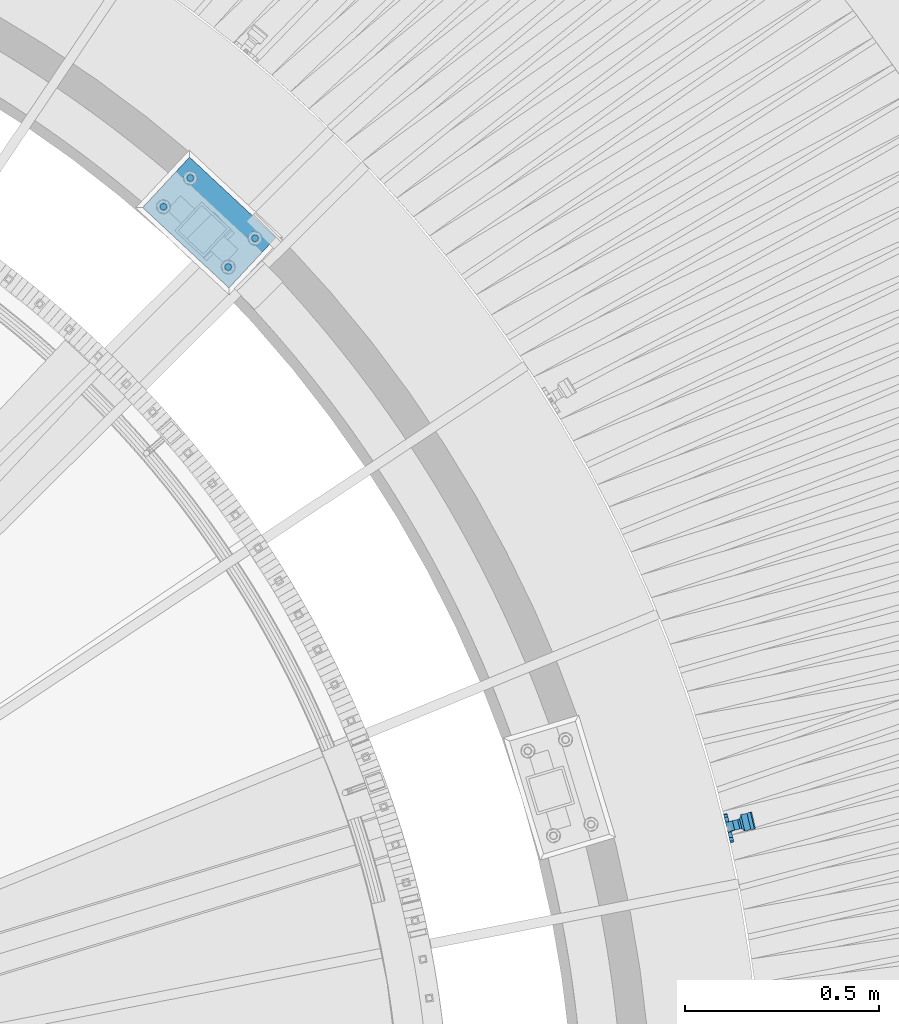
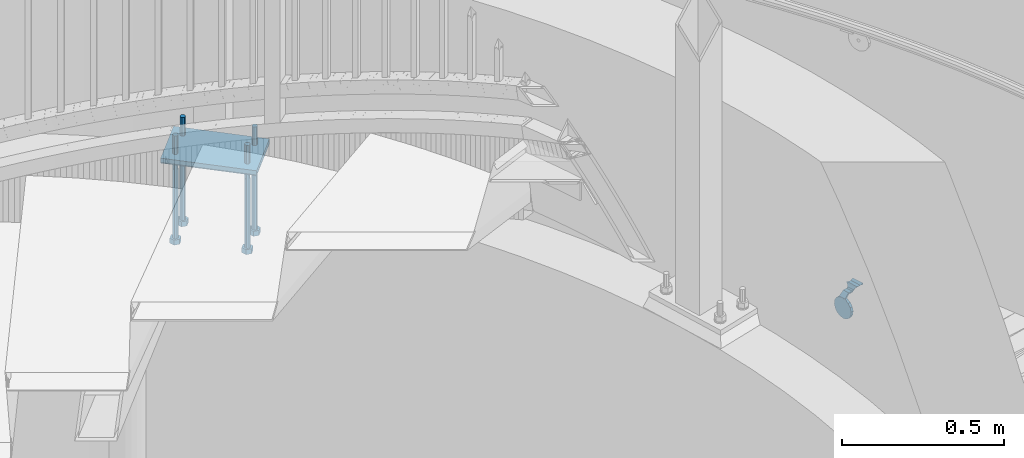
# One storey, part 511 of 975: 7 beams.
"""IFC2X3 building model written with IfcOpenShell, lengths in millimetres."""

from ifc_helpers import new_model, si_unit, frame, origin_with_axes, place, context, subcontext, project, spatial, faceted_brep, material, type_object, element, save


model = new_model("IFC2X3")

# Units and contexts
model_context = context("Model", 3, precision=1e-05, world=origin_with_axes())
body_context = subcontext(model_context, "Body", "Model", "MODEL_VIEW")
ifc_project = project(units=[si_unit("LENGTHUNIT", "METRE", prefix="MILLI"), si_unit("AREAUNIT", "SQUARE_METRE"), si_unit("VOLUMEUNIT", "CUBIC_METRE"), si_unit("MASSUNIT", "GRAM", prefix="KILO"), si_unit("TIMEUNIT", "SECOND"), si_unit("PLANEANGLEUNIT", "RADIAN"), si_unit("SOLIDANGLEUNIT", "STERADIAN"), si_unit("THERMODYNAMICTEMPERATUREUNIT", "DEGREE_CELSIUS"), si_unit("LUMINOUSINTENSITYUNIT", "LUMEN")], contexts=[model_context])

# Site, building, storey
site_placement = place(None, origin_with_axes())
site = spatial("IfcSite", under=ifc_project, at=site_placement, CompositionType="ELEMENT")
building_placement = place(site_placement, origin_with_axes())
building = spatial("IfcBuilding", under=site, at=building_placement, Name="Undefined", CompositionType="ELEMENT")
storey_placement = place(building_placement, origin_with_axes())
storey = spatial("IfcBuildingStorey", under=building, at=storey_placement, Name="Undefined", CompositionType="ELEMENT", Elevation=0.0)

# Beams
ifc_material_1 = material(Name="STEEL/A36")
beam_type_1 = type_object("IfcBeamType", PredefinedType="NOTDEFINED")
beam_1_placement = place(storey_placement, frame((38352.7590632473, 4258.52106248516, 1307.77285359091), z_axis=(-0.230600537056045, 0.970132516235566, -0.0752747849675684), x_axis=(-0.972893254787277, -0.231254651949474, 2.72239999874042e-05)))
element("IfcBeam", 1, at=beam_1_placement, inside=storey, type_object=beam_type_1, material=ifc_material_1, Name="WALL BRACKET", context=body_context, shape_type="Brep", body=[
    faceted_brep([(-1.09139364212751e-11, -35.1998101886752, 14.5802387730655), (0.0, -26.940768363208, 26.9407683632162), (1.2732925824821e-11, -14.5802387731151, 35.1998101887366), (0.0, 0.0, 38.0999984741211), (3.27418092638254e-11, 14.5802387730973, 35.1998101888166), (3.45607986673713e-11, 26.9407683631939, 26.9407683633472), (3.27418092638254e-11, 35.1998101886679, 14.5802387732328), (2.36468622460961e-11, 38.0999999999908, 8.73114913702011e-11), (1.45519152283669e-11, 35.1998101886752, -14.5802387730655), (1.81898940354586e-12, 26.9407683632071, -26.9407683632162), (-1.09139364212751e-11, 14.5802387731146, -35.1998101887511), (0.0, 0.0, -38.0999984741211), (-2.91038304567337e-11, -14.5802387730978, -35.1998101888239), (-3.27418092638254e-11, -26.9407683631948, -26.9407683633617), (-3.09228198602796e-11, -35.1998101886688, -14.5802387732401), (-2.36468622460961e-11, -38.0999999999917, -9.45874489843845e-11), (9.52499999999407, 35.4440469783465, 13.3523775149006), (9.52500000001783, 38.099999999989, 1.23691279441118e-10), (5.45819490078651, 35.1998101886775, 14.58023877304), (5.15915812204861, 35.4440469814256, 13.3523774994246), (5.15916016817869, 35.4440461871586, -13.3523814925829), (5.45819607316758, 35.1998101886757, -14.5802387731565), (9.52499999563867, 35.4440461839649, -13.352381508641), (9.52499999999338, 33.7468954266617, -16.754679378646), (9.52499999999418, 26.9407683632057, -26.9407683631944), (7.23710514487385, 33.7468954167059, -16.7546793935435), (9.52499999997963, 14.5802387731133, -35.199810188722), (9.52499999996871, 7.73070496506989e-12, -38.1000000000931), (9.52499999996326, -14.5802387730996, -35.1998101888021), (9.52499999995962, -26.9407683631966, -26.9407683633399), (9.5249999999578, -35.1998101886768, -14.5802387731064), (9.52499999997235, -38.0999999999935, -7.27595761418343e-11), (9.52499999988504, -35.1998101886779, 14.5802387731401), (9.52499999999418, -26.9407683632098, 26.940768363238), (9.52500000000691, -14.5802387731169, 35.1998101887584), (9.52500000001783, -1.13686837721616e-11, 38.1000000001295), (9.5250000000251, 14.580238773096, 35.1998101888312), (9.52500000002692, 26.9407683631925, 26.9407683633617), (7.23710629084189, 33.7468933804012, 16.7546824409801), (9.52500001802099, 33.74689339, 16.7546824266137), (4.12737783423069, 36.2867482851609, 11.6630037101459), (9.52500001480979, 36.2867482910076, 11.6630037099276), (1.9072828969438, 38.0999998001848, -4.3824766180478e-06), (9.43529109937867, 38.0999998083389, -4.38277129433118e-06), (4.12738199474541, 36.2867456530334, -11.6630120660157), (9.52499999713365, 36.2867456588801, -11.6630120662267), (9.52499998931302, 31.8782691818908, -20.5007361535354), (1.90728516843444, 38.0999984362613, -14.9620414784949), (9.43529504267332, 38.0999984471014, -14.9620414798228), (9.52499998867484, 31.8782692100656, -21.3428983101403), (-0.974480980704527, 40.4536660864392, -13.6176374922397), (6.55352889353486, 40.4536660972792, -13.617637493564), (-3.23293929398841, 48.4467136552532, -12.2071016444133), (-3.86099316375032, 48.9596734302611, -12.3332393299024), (-3.86099415506237, 48.9596734359397, 12.1506042690053), (-3.23294234398753, 48.4467162038179, 12.0244673261113), (6.55352388489973, 40.4536689343606, 13.4350048968336), (9.4352891744017, 38.1000015670843, 14.7794093900302), (-8.88876894391092, 51.462646060533, -12.9487245784876), (-14.5044020842531, 51.5524567377918, -12.9708091785214), (-14.5044031272276, 51.5524567437842, 12.788173508583), (-8.88876998507754, 51.4626460665079, 12.7660889411018), (-16.4483770195459, 51.1442726592504, -12.8704360163174), (-16.4483780543928, 51.1442726651987, 12.6878004343525), (-22.5793182144077, 51.3711360271759, -12.9262221073186), (-22.5793192537777, 51.3711360331463, 12.7435864607032), (-27.8885284154861, 54.4455780358899, -13.6822326528272), (-27.8885295160832, 54.4455780422152, 13.4995963000001), (-28.6196515649072, 55.6169452716154, -13.9702738582564), (-31.1370083013608, 59.6501226213948, -17.5950925222933), (-31.1370097188383, 59.6501226295447, 17.4124524185645), (-28.6196545294583, 55.616948227025, 13.7876379643458), (-33.6296792490059, 67.324805151891, -22.2250062266612), (-32.8101722890036, 64.8016260361878, -22.2250061928717), (-39.3161821982224, 64.9509398614337, -22.2250064563596), (-33.6296810489844, 67.3248051619378, 22.2249937734341), (-39.3127719838823, 64.95236112884, 22.2249935438595), (-32.8101756191698, 64.8016307577993, 22.2249938072164), (-49.8281982508399, 63.7590297560901, -21.2879733583577), (-49.8281999673757, 63.7590297658239, 21.1053316176076), (-62.537662592724, 64.8016282183019, -22.2250073966388), (-62.5376643923654, 64.8016282284259, 22.2249926034456), (-59.3629825026719, 68.3509998487543, 22.2249927311568), (-59.3629807030303, 68.3509998386305, -22.2250072689349), (-56.0005505059879, 61.6533412669896, 22.2249928688907), (-56.0009816237271, 61.6535489521873, 19.2130312653135), (-56.0009816302269, 64.8016307505561, 22.0423689734525), (-51.9930603186979, 64.8016307660225, 22.2249930304133), (-51.9930486616773, 64.8016260085653, -22.2250069696784), (-56.000981616694, 61.6535497473442, -22.2250071312228), (-56.0009816212363, 64.8016260027941, -22.2250068759422), (-56.0009816161877, 61.6535496925769, -19.3956728877092), (-50.6240356350016, 59.0640018412871, -17.0683164176735), (-50.6240370098228, 59.0640018490833, 16.8856764812081), (-37.4851004069614, 60.555058921409, -18.4084041452843), (-37.4851018904596, 60.555058929803, 18.2257636742615), (-36.5628425975134, 60.9400579463424, -18.7544220673662), (-36.5628441090176, 60.9400579547794, 18.5717814508498), (-35.6661101826384, 58.1791091500552, -16.2730189810172), (-35.6661114930633, 58.1791091575863, 16.0903794298065), (-34.0669073739811, 55.616948225869, 13.7876379531408), (-34.0669044052501, 55.6169452637716, -13.9702738572996), (-31.199578137138, 51.0230652214489, -12.8406309028251), (-31.1995791695818, 51.0230652273826, 12.6579953160217), (-13.5258453474495, 46.8920843628518, -12.4814476045976), (-10.0158535806146, 46.8359491542703, -12.491353805628), (-10.0158545847443, 46.8359491600327, 12.308720278641), (-13.5258463507973, 46.8920843686235, 12.298814059428), (-15.4698202757649, 46.4839002842855, -12.5534799881534), (-15.469821284944, 46.4839002900824, 12.3708465294185), (-23.8996230795056, 46.7958284847284, -12.4984339079674), (-23.8996240842331, 46.7958284904998, 12.3158003666576), (-26.7505131823156, 48.4467136213889, -12.207101640266), (-26.7505186046602, 48.4467161988273, 12.0244672777189), (-6.87329577845111, 45.2714927334573, -12.7674339683217), (-6.87329680492121, 45.2714927393397, 12.584800790275), (-0.974485553301008, 40.4536689327629, 13.4350048813394), (1.90728014135857, 38.100001565487, 14.7794093745397), (9.52500002100476, 31.8782677827221, 21.320715892205), (9.52500002038346, 31.878267810155, 20.5007393728483)], [[[0, 1, 2, 3, 4, 5, 6, 7, 8, 9, 10, 11, 12, 13, 14, 15]], [[16, 17, 7, 6, 18, 19]], [[20, 21, 8, 7, 17, 22]], [[23, 24, 9, 8, 21, 25]], [[10, 9, 24, 26]], [[11, 10, 26, 27]], [[12, 11, 27, 28]], [[13, 12, 28, 29]], [[14, 13, 29, 30]], [[15, 14, 30, 31]], [[0, 15, 31, 32]], [[1, 0, 32, 33]], [[2, 1, 33, 34]], [[3, 2, 34, 35]], [[4, 3, 35, 36]], [[5, 4, 36, 37]], [[38, 18, 6, 5, 37, 39]], [[39, 37, 36, 35, 34, 33, 32, 31, 30, 29, 28, 27, 26, 24, 23, 22, 17, 16]], [[40, 41, 16, 19]], [[40, 42, 43, 41]], [[42, 44, 45, 43]], [[46, 23, 25]], [[47, 48, 49]], [[48, 47, 50, 51]], [[51, 52, 53, 54, 55, 56, 57, 48]], [[58, 59, 60, 61]], [[59, 62, 63, 60]], [[62, 64, 65, 63]], [[64, 66, 67, 65]], [[66, 68, 69, 70, 71, 67]], [[72, 73, 74]], [[75, 76, 77]], [[74, 76, 75, 72]], [[74, 78, 79, 76]], [[80, 81, 82, 83]], [[84, 85, 86]], [[82, 81, 84, 86, 87]], [[78, 88, 83, 82, 87, 79]], [[89, 80, 83, 88, 90]], [[89, 90, 91]], [[84, 81, 80, 89, 91, 92, 93, 85]], [[92, 94, 95, 93]], [[94, 96, 97, 95]], [[96, 98, 99, 97]], [[70, 77, 76, 79, 87, 86, 85, 93, 95, 97, 99, 100, 71]], [[69, 73, 72, 75, 77, 70]], [[68, 101, 98, 96, 94, 92, 91, 90, 88, 78, 74, 73, 69]], [[99, 98, 101, 102, 103, 100]], [[104, 105, 106, 107]], [[108, 104, 107, 109]], [[110, 108, 109, 111]], [[103, 102, 112, 110, 111, 113]], [[54, 61, 60, 63, 65, 67, 71, 100, 103, 113, 55]], [[53, 58, 61, 54]], [[52, 112, 102, 101, 68, 66, 64, 62, 59, 58, 53]], [[51, 50, 114, 105, 104, 108, 110, 112, 52]], [[105, 114, 115, 106]], [[55, 113, 111, 109, 107, 106, 115, 116, 56]], [[56, 116, 117, 57]], [[117, 118, 57]], [[39, 16, 41, 43, 45, 22, 23, 46, 49, 48, 57, 118, 119]], [[119, 38, 39]], [[119, 118, 117, 116, 115, 114, 50, 47, 49, 46, 25, 21, 20, 44, 42, 40, 19, 18, 38]], [[45, 44, 20, 22]]]),
])
ifc_material_2 = material(Name="STEEL/F1554-36")
beam_type_2 = type_object("IfcBeamType", PredefinedType="NOTDEFINED")
beam_2_placement = place(storey_placement, frame((37124.3022421513, 5781.13190493338, 1371.6), z_axis=(-0.73176109614993, 0.68156122113971, 0.0), x_axis=(0.0, 0.0, -1.0)))
element("IfcBeam", 2, at=beam_2_placement, inside=storey, type_object=beam_type_2, material=ifc_material_2, Name="HEADED_ANCHOR_BOLT", context=body_context, shape_type="Brep", body=[
    faceted_brep([(260.34375, -9.13000011445183, 15.8100004195221), (260.34375, -18.2600002289691, -1.45519152283669e-11), (279.393749999999, -18.2600002289691, -1.45519152283669e-11), (279.393749999999, -9.13000011445183, 15.8100004195221), (260.34375, 9.13000011451732, 15.8100004195403), (279.393749999999, 9.13000011451732, 15.8100004195403), (260.34375, 18.2600002289728, 1.81898940354586e-11), (279.393749999999, 18.2600002289728, 1.81898940354586e-11), (260.34375, 9.13000011445547, -15.8100004195221), (279.393749999999, 9.13000011445547, -15.8100004195221), (260.34375, -9.13000011451732, -15.8100004195367), (279.393749999999, -9.13000011451732, -15.8100004195367), (260.34375, -4.47768005528269, 9.29799844174704), (260.34375, -8.06850066050174, 6.43441456486471), (260.34375, -10.0612557562381, 2.29641597050068), (260.34375, -10.0612557562454, -2.29641597051523), (260.34375, -8.06850066052721, -6.43441456487926), (260.34375, -4.47768005531907, -9.29799844175068), (260.34375, -1.81898940354586e-11, -10.319999694766), (260.34375, 4.47768005528633, -9.2979984417434), (260.34375, 8.06850066050174, -6.43441456486471), (260.34375, 10.0612557562381, -2.29641597050068), (260.34375, 10.0612557562454, 2.29641597051886), (260.34375, 8.06850066052357, 6.4344145648829), (260.34375, 4.47768005532271, 9.29799844175432), (260.34375, 2.18278728425503e-11, 10.3199996947696), (279.393749999999, 2.18278728425503e-11, 10.3199996947696), (279.393749999999, -4.47768005528269, 9.29799844174704), (279.393749999999, -8.06850066050174, 6.43441456486471), (279.393749999999, -10.0612557562381, 2.29641597050068), (279.393749999999, -10.0612557562454, -2.29641597051523), (279.393749999999, -8.06850066052721, -6.43441456487926), (279.393749999999, -4.47768005531907, -9.29799844175068), (279.393749999999, -1.81898940354586e-11, -10.319999694766), (279.393749999999, 4.47768005528633, -9.2979984417434), (279.393749999999, 8.06850066050174, -6.43441456486471), (279.393749999999, 10.0612557562381, -2.29641597050068), (279.393749999999, 10.0612557562454, 2.29641597051886), (279.393749999999, 8.06850066052357, 6.4344145648829), (279.393749999999, 4.47768005532271, 9.29799844175432), (0.0, -6.73519209080223, 6.73519209080186), (0.0, -9.52499999999964, 0.0), (279.400000000001, -9.52499999999782, -3.63797880709171e-12), (279.400000000001, -6.73519209079313, 6.73519209079313), (-9.87109982941227e-13, -1.20792265079217e-13, 9.52499961853027), (279.400000000001, 1.09139364212751e-11, 9.52499999999054), (0.0, 6.73519209080223, 6.73519209080186), (279.400000000001, 6.73519209081132, 6.73519209079677), (0.0, 9.52499999999964, 0.0), (279.400000000001, 9.52500000000146, 3.63797880709171e-12), (0.0, 6.73519209080223, -6.73519209080186), (279.400000000001, 6.73519209079677, -6.73519209079313), (2.95075507493764e-12, -1.20792265079217e-13, -9.52499961853027), (279.400000000001, -1.09139364212751e-11, -9.5249999999869), (-126.99791499542, -6.36396103070001, 6.3639610306418), (-126.99791499542, 1.81898940354586e-11, 8.99999999995271), (-126.99791499542, 6.36396103072184, 6.36396103065272), (-126.99791499542, 9.00000000004366, 1.09139364212751e-11), (-126.99791499542, 6.36396103069637, -6.3639610306418), (-126.99791499542, -1.81898940354586e-11, -8.99999999995271), (-126.99791499542, -6.36396103072184, -6.36396103064908), (-126.99791499542, -9.00000000004002, -7.27595761418343e-12), (0.0149743263646087, 6.36396103067818, -6.36396103067909), (0.0149743263646087, 0.0, -9.0), (0.0149743263646087, -6.36396103067818, -6.36396103067909), (0.0149743263987148, -8.9999995411581, -1.00796984270346e-06), (0.0149743263646087, -6.36396103067818, 6.36396103067909), (0.0149743263646087, 0.0, 9.0), (0.0149743263646087, 6.36396103067818, 6.36396103067909), (0.0149743263987148, 9.0000004588419, -1.00796984270346e-06), (0.0, -6.73519209080223, -6.73519209080186), (279.400000000001, -6.73519209080769, -6.73519209079677)], [[[0, 1, 2, 3]], [[4, 0, 3, 5]], [[6, 4, 5, 7]], [[8, 6, 7, 9]], [[10, 8, 9, 11]], [[0, 4, 6, 8, 10, 1], [12, 13, 14, 15, 16, 17, 18, 19, 20, 21, 22, 23, 24, 25]], [[12, 25, 26, 27]], [[13, 12, 27, 28]], [[14, 13, 28, 29]], [[15, 14, 29, 30]], [[16, 15, 30, 31]], [[17, 16, 31, 32]], [[18, 17, 32, 33]], [[19, 18, 33, 34]], [[20, 19, 34, 35]], [[21, 20, 35, 36]], [[22, 21, 36, 37]], [[23, 22, 37, 38]], [[24, 23, 38, 39]], [[25, 24, 39, 26]], [[9, 7, 5, 3, 2, 11], [38, 37, 36, 35, 34, 33, 32, 31, 30, 29, 28, 27, 26, 39]], [[1, 10, 11, 2]], [[40, 41, 42, 43]], [[44, 40, 43, 45]], [[46, 44, 45, 47]], [[48, 46, 47, 49]], [[50, 48, 49, 51]], [[52, 50, 51, 53]], [[54, 55, 56, 57, 58, 59, 60, 61]], [[59, 58, 62, 63]], [[60, 59, 63, 64]], [[61, 60, 64, 65]], [[54, 61, 65, 66]], [[55, 54, 66, 67]], [[56, 55, 67, 68]], [[57, 56, 68, 69]], [[58, 57, 69, 62]], [[40, 44, 46, 48, 50, 52, 70, 41], [68, 67, 66, 65, 64, 63, 62, 69]], [[41, 70, 71, 42]], [[53, 51, 49, 47, 45, 43, 42, 71]], [[70, 52, 53, 71]]]),
])
beam_3_placement = place(storey_placement, frame((37055.0556265495, 5706.78497340274, 1371.6), z_axis=(0.73176109614993, -0.68156122113971, 0.0), x_axis=(0.0, 0.0, -1.0)))
element("IfcBeam", 3, at=beam_3_placement, inside=storey, type_object=beam_type_2, material=ifc_material_2, Name="HEADED_ANCHOR_BOLT", context=body_context, shape_type="Brep", body=[
    faceted_brep([(260.34375, -9.13000011445183, 15.8100004195221), (260.34375, -18.2600002289691, -1.45519152283669e-11), (279.393749999999, -18.2600002289691, -1.45519152283669e-11), (279.393749999999, -9.13000011445183, 15.8100004195221), (260.34375, 9.13000011451732, 15.8100004195403), (279.393749999999, 9.13000011451732, 15.8100004195403), (260.34375, 18.2600002289728, 1.81898940354586e-11), (279.393749999999, 18.2600002289728, 1.81898940354586e-11), (260.34375, 9.13000011445547, -15.8100004195221), (279.393749999999, 9.13000011445547, -15.8100004195221), (260.34375, -9.13000011451732, -15.8100004195367), (279.393749999999, -9.13000011451732, -15.8100004195367), (260.34375, -4.47768005528269, 9.29799844174704), (260.34375, -8.06850066050174, 6.43441456486471), (260.34375, -10.0612557562381, 2.29641597050068), (260.34375, -10.0612557562454, -2.29641597051523), (260.34375, -8.06850066052721, -6.43441456487926), (260.34375, -4.47768005531907, -9.29799844175068), (260.34375, -1.81898940354586e-11, -10.319999694766), (260.34375, 4.47768005528633, -9.2979984417434), (260.34375, 8.06850066050174, -6.43441456486471), (260.34375, 10.0612557562381, -2.29641597050068), (260.34375, 10.0612557562454, 2.29641597051886), (260.34375, 8.06850066052357, 6.4344145648829), (260.34375, 4.47768005532271, 9.29799844175432), (260.34375, 2.18278728425503e-11, 10.3199996947696), (279.393749999999, 2.18278728425503e-11, 10.3199996947696), (279.393749999999, -4.47768005528269, 9.29799844174704), (279.393749999999, -8.06850066050174, 6.43441456486471), (279.393749999999, -10.0612557562381, 2.29641597050068), (279.393749999999, -10.0612557562454, -2.29641597051523), (279.393749999999, -8.06850066052721, -6.43441456487926), (279.393749999999, -4.47768005531907, -9.29799844175068), (279.393749999999, -1.81898940354586e-11, -10.319999694766), (279.393749999999, 4.47768005528633, -9.2979984417434), (279.393749999999, 8.06850066050174, -6.43441456486471), (279.393749999999, 10.0612557562381, -2.29641597050068), (279.393749999999, 10.0612557562454, 2.29641597051886), (279.393749999999, 8.06850066052357, 6.4344145648829), (279.393749999999, 4.47768005532271, 9.29799844175432), (0.0, -6.73519209080223, 6.73519209080186), (0.0, -9.52499999999964, 0.0), (279.400000000001, -9.52499999999782, -3.63797880709171e-12), (279.400000000001, -6.73519209079313, 6.73519209079313), (-9.87109982941227e-13, -1.20792265079217e-13, 9.52499961853027), (279.400000000001, 1.09139364212751e-11, 9.52499999999054), (0.0, 6.73519209080223, 6.73519209080186), (279.400000000001, 6.73519209081132, 6.73519209079677), (0.0, 9.52499999999964, 0.0), (279.400000000001, 9.52500000000146, 3.63797880709171e-12), (0.0, 6.73519209080223, -6.73519209080186), (279.400000000001, 6.73519209079677, -6.73519209079313), (2.95075507493764e-12, -1.20792265079217e-13, -9.52499961853027), (279.400000000001, -1.09139364212751e-11, -9.5249999999869), (-126.99791499542, -6.36396103070001, 6.3639610306418), (-126.99791499542, 1.81898940354586e-11, 8.99999999995271), (-126.99791499542, 6.36396103072184, 6.36396103065272), (-126.99791499542, 9.00000000004366, 1.09139364212751e-11), (-126.99791499542, 6.36396103069637, -6.3639610306418), (-126.99791499542, -1.81898940354586e-11, -8.99999999995271), (-126.99791499542, -6.36396103072184, -6.36396103064908), (-126.99791499542, -9.00000000004002, -7.27595761418343e-12), (0.0149743263646087, 6.36396103067818, -6.36396103067909), (0.0149743263646087, 0.0, -9.0), (0.0149743263646087, -6.36396103067818, -6.36396103067909), (0.0149743263987148, -8.9999995411581, -1.00796984270346e-06), (0.0149743263646087, -6.36396103067818, 6.36396103067909), (0.0149743263646087, 0.0, 9.0), (0.0149743263646087, 6.36396103067818, 6.36396103067909), (0.0149743263987148, 9.0000004588419, -1.00796984270346e-06), (0.0, -6.73519209080223, -6.73519209080186), (279.400000000001, -6.73519209080769, -6.73519209079677)], [[[0, 1, 2, 3]], [[4, 0, 3, 5]], [[6, 4, 5, 7]], [[8, 6, 7, 9]], [[10, 8, 9, 11]], [[0, 4, 6, 8, 10, 1], [12, 13, 14, 15, 16, 17, 18, 19, 20, 21, 22, 23, 24, 25]], [[12, 25, 26, 27]], [[13, 12, 27, 28]], [[14, 13, 28, 29]], [[15, 14, 29, 30]], [[16, 15, 30, 31]], [[17, 16, 31, 32]], [[18, 17, 32, 33]], [[19, 18, 33, 34]], [[20, 19, 34, 35]], [[21, 20, 35, 36]], [[22, 21, 36, 37]], [[23, 22, 37, 38]], [[24, 23, 38, 39]], [[25, 24, 39, 26]], [[9, 7, 5, 3, 2, 11], [38, 37, 36, 35, 34, 33, 32, 31, 30, 29, 28, 27, 26, 39]], [[1, 10, 11, 2]], [[40, 41, 42, 43]], [[44, 40, 43, 45]], [[46, 44, 45, 47]], [[48, 46, 47, 49]], [[50, 48, 49, 51]], [[52, 50, 51, 53]], [[54, 55, 56, 57, 58, 59, 60, 61]], [[59, 58, 62, 63]], [[60, 59, 63, 64]], [[61, 60, 64, 65]], [[54, 61, 65, 66]], [[55, 54, 66, 67]], [[56, 55, 67, 68]], [[57, 56, 68, 69]], [[58, 57, 69, 62]], [[40, 44, 46, 48, 50, 52, 70, 41], [68, 67, 66, 65, 64, 63, 62, 69]], [[41, 70, 71, 42]], [[53, 51, 49, 47, 45, 43, 42, 71]], [[70, 52, 53, 71]]]),
])
beam_4_placement = place(storey_placement, frame((36887.7750399706, 5862.58986855396, 1371.6), z_axis=(0.73176109614993, -0.68156122113971, 0.0), x_axis=(0.0, 0.0, -1.0)))
element("IfcBeam", 4, at=beam_4_placement, inside=storey, type_object=beam_type_2, material=ifc_material_2, Name="HEADED_ANCHOR_BOLT", context=body_context, shape_type="Brep", body=[
    faceted_brep([(260.34375, -9.13000011445183, 15.8100004195221), (260.34375, -18.2600002289691, -1.45519152283669e-11), (279.393749999999, -18.2600002289691, -1.45519152283669e-11), (279.393749999999, -9.13000011445183, 15.8100004195221), (260.34375, 9.13000011451732, 15.8100004195403), (279.393749999999, 9.13000011451732, 15.8100004195403), (260.34375, 18.2600002289728, 1.81898940354586e-11), (279.393749999999, 18.2600002289728, 1.81898940354586e-11), (260.34375, 9.13000011445547, -15.8100004195221), (279.393749999999, 9.13000011445547, -15.8100004195221), (260.34375, -9.13000011451732, -15.8100004195367), (279.393749999999, -9.13000011451732, -15.8100004195367), (260.34375, -4.47768005528269, 9.29799844174704), (260.34375, -8.06850066050174, 6.43441456486471), (260.34375, -10.0612557562381, 2.29641597050068), (260.34375, -10.0612557562454, -2.29641597051523), (260.34375, -8.06850066052721, -6.43441456487926), (260.34375, -4.47768005531907, -9.29799844175068), (260.34375, -1.81898940354586e-11, -10.319999694766), (260.34375, 4.47768005528633, -9.2979984417434), (260.34375, 8.06850066050174, -6.43441456486471), (260.34375, 10.0612557562381, -2.29641597050068), (260.34375, 10.0612557562454, 2.29641597051886), (260.34375, 8.06850066052357, 6.4344145648829), (260.34375, 4.47768005532271, 9.29799844175432), (260.34375, 2.18278728425503e-11, 10.3199996947696), (279.393749999999, 2.18278728425503e-11, 10.3199996947696), (279.393749999999, -4.47768005528269, 9.29799844174704), (279.393749999999, -8.06850066050174, 6.43441456486471), (279.393749999999, -10.0612557562381, 2.29641597050068), (279.393749999999, -10.0612557562454, -2.29641597051523), (279.393749999999, -8.06850066052721, -6.43441456487926), (279.393749999999, -4.47768005531907, -9.29799844175068), (279.393749999999, -1.81898940354586e-11, -10.319999694766), (279.393749999999, 4.47768005528633, -9.2979984417434), (279.393749999999, 8.06850066050174, -6.43441456486471), (279.393749999999, 10.0612557562381, -2.29641597050068), (279.393749999999, 10.0612557562454, 2.29641597051886), (279.393749999999, 8.06850066052357, 6.4344145648829), (279.393749999999, 4.47768005532271, 9.29799844175432), (0.0, -6.73519209080223, 6.73519209080186), (0.0, -9.52499999999964, 0.0), (279.400000000001, -9.52499999999782, -3.63797880709171e-12), (279.400000000001, -6.73519209079313, 6.73519209079313), (-9.87109982941227e-13, -1.20792265079217e-13, 9.52499961853027), (279.400000000001, 1.09139364212751e-11, 9.52499999999054), (0.0, 6.73519209080223, 6.73519209080186), (279.400000000001, 6.73519209081132, 6.73519209079677), (0.0, 9.52499999999964, 0.0), (279.400000000001, 9.52500000000146, 3.63797880709171e-12), (0.0, 6.73519209080223, -6.73519209080186), (279.400000000001, 6.73519209079677, -6.73519209079313), (2.95075507493764e-12, -1.20792265079217e-13, -9.52499961853027), (279.400000000001, -1.09139364212751e-11, -9.5249999999869), (-126.99791499542, -6.36396103070001, 6.3639610306418), (-126.99791499542, 1.81898940354586e-11, 8.99999999995271), (-126.99791499542, 6.36396103072184, 6.36396103065272), (-126.99791499542, 9.00000000004366, 1.09139364212751e-11), (-126.99791499542, 6.36396103069637, -6.3639610306418), (-126.99791499542, -1.81898940354586e-11, -8.99999999995271), (-126.99791499542, -6.36396103072184, -6.36396103064908), (-126.99791499542, -9.00000000004002, -7.27595761418343e-12), (0.0149743263646087, 6.36396103067818, -6.36396103067909), (0.0149743263646087, 0.0, -9.0), (0.0149743263646087, -6.36396103067818, -6.36396103067909), (0.0149743263987148, -8.9999995411581, -1.00796984270346e-06), (0.0149743263646087, -6.36396103067818, 6.36396103067909), (0.0149743263646087, 0.0, 9.0), (0.0149743263646087, 6.36396103067818, 6.36396103067909), (0.0149743263987148, 9.0000004588419, -1.00796984270346e-06), (0.0, -6.73519209080223, -6.73519209080186), (279.400000000001, -6.73519209080769, -6.73519209079677)], [[[0, 1, 2, 3]], [[4, 0, 3, 5]], [[6, 4, 5, 7]], [[8, 6, 7, 9]], [[10, 8, 9, 11]], [[0, 4, 6, 8, 10, 1], [12, 13, 14, 15, 16, 17, 18, 19, 20, 21, 22, 23, 24, 25]], [[12, 25, 26, 27]], [[13, 12, 27, 28]], [[14, 13, 28, 29]], [[15, 14, 29, 30]], [[16, 15, 30, 31]], [[17, 16, 31, 32]], [[18, 17, 32, 33]], [[19, 18, 33, 34]], [[20, 19, 34, 35]], [[21, 20, 35, 36]], [[22, 21, 36, 37]], [[23, 22, 37, 38]], [[24, 23, 38, 39]], [[25, 24, 39, 26]], [[9, 7, 5, 3, 2, 11], [38, 37, 36, 35, 34, 33, 32, 31, 30, 29, 28, 27, 26, 39]], [[1, 10, 11, 2]], [[40, 41, 42, 43]], [[44, 40, 43, 45]], [[46, 44, 45, 47]], [[48, 46, 47, 49]], [[50, 48, 49, 51]], [[52, 50, 51, 53]], [[54, 55, 56, 57, 58, 59, 60, 61]], [[59, 58, 62, 63]], [[60, 59, 63, 64]], [[61, 60, 64, 65]], [[54, 61, 65, 66]], [[55, 54, 66, 67]], [[56, 55, 67, 68]], [[57, 56, 68, 69]], [[58, 57, 69, 62]], [[40, 44, 46, 48, 50, 52, 70, 41], [68, 67, 66, 65, 64, 63, 62, 69]], [[41, 70, 71, 42]], [[53, 51, 49, 47, 45, 43, 42, 71]], [[70, 52, 53, 71]]]),
])
beam_5_placement = place(storey_placement, frame((36957.0216555736, 5936.9368000835, 1371.6), z_axis=(-0.73176109614993, 0.68156122113971, 0.0), x_axis=(0.0, 0.0, -1.0)))
element("IfcBeam", 5, at=beam_5_placement, inside=storey, type_object=beam_type_2, material=ifc_material_2, Name="HEADED_ANCHOR_BOLT", context=body_context, shape_type="Brep", body=[
    faceted_brep([(260.34375, -9.13000011445183, 15.8100004195221), (260.34375, -18.2600002289691, -1.45519152283669e-11), (279.393749999999, -18.2600002289691, -1.45519152283669e-11), (279.393749999999, -9.13000011445183, 15.8100004195221), (260.34375, 9.13000011451732, 15.8100004195403), (279.393749999999, 9.13000011451732, 15.8100004195403), (260.34375, 18.2600002289728, 1.81898940354586e-11), (279.393749999999, 18.2600002289728, 1.81898940354586e-11), (260.34375, 9.13000011445547, -15.8100004195221), (279.393749999999, 9.13000011445547, -15.8100004195221), (260.34375, -9.13000011451732, -15.8100004195367), (279.393749999999, -9.13000011451732, -15.8100004195367), (260.34375, -4.47768005528269, 9.29799844174704), (260.34375, -8.06850066050174, 6.43441456486471), (260.34375, -10.0612557562381, 2.29641597050068), (260.34375, -10.0612557562454, -2.29641597051523), (260.34375, -8.06850066052721, -6.43441456487926), (260.34375, -4.47768005531907, -9.29799844175068), (260.34375, -1.81898940354586e-11, -10.319999694766), (260.34375, 4.47768005528633, -9.2979984417434), (260.34375, 8.06850066050174, -6.43441456486471), (260.34375, 10.0612557562381, -2.29641597050068), (260.34375, 10.0612557562454, 2.29641597051886), (260.34375, 8.06850066052357, 6.4344145648829), (260.34375, 4.47768005532271, 9.29799844175432), (260.34375, 2.18278728425503e-11, 10.3199996947696), (279.393749999999, 2.18278728425503e-11, 10.3199996947696), (279.393749999999, -4.47768005528269, 9.29799844174704), (279.393749999999, -8.06850066050174, 6.43441456486471), (279.393749999999, -10.0612557562381, 2.29641597050068), (279.393749999999, -10.0612557562454, -2.29641597051523), (279.393749999999, -8.06850066052721, -6.43441456487926), (279.393749999999, -4.47768005531907, -9.29799844175068), (279.393749999999, -1.81898940354586e-11, -10.319999694766), (279.393749999999, 4.47768005528633, -9.2979984417434), (279.393749999999, 8.06850066050174, -6.43441456486471), (279.393749999999, 10.0612557562381, -2.29641597050068), (279.393749999999, 10.0612557562454, 2.29641597051886), (279.393749999999, 8.06850066052357, 6.4344145648829), (279.393749999999, 4.47768005532271, 9.29799844175432), (0.0, -6.73519209080223, 6.73519209080186), (0.0, -9.52499999999964, 0.0), (279.400000000001, -9.52499999999782, -3.63797880709171e-12), (279.400000000001, -6.73519209079313, 6.73519209079313), (-9.87109982941227e-13, -1.20792265079217e-13, 9.52499961853027), (279.400000000001, 1.09139364212751e-11, 9.52499999999054), (0.0, 6.73519209080223, 6.73519209080186), (279.400000000001, 6.73519209081132, 6.73519209079677), (0.0, 9.52499999999964, 0.0), (279.400000000001, 9.52500000000146, 3.63797880709171e-12), (0.0, 6.73519209080223, -6.73519209080186), (279.400000000001, 6.73519209079677, -6.73519209079313), (2.95075507493764e-12, -1.20792265079217e-13, -9.52499961853027), (279.400000000001, -1.09139364212751e-11, -9.5249999999869), (-126.99791499542, -6.36396103070001, 6.3639610306418), (-126.99791499542, 1.81898940354586e-11, 8.99999999995271), (-126.99791499542, 6.36396103072184, 6.36396103065272), (-126.99791499542, 9.00000000004366, 1.09139364212751e-11), (-126.99791499542, 6.36396103069637, -6.3639610306418), (-126.99791499542, -1.81898940354586e-11, -8.99999999995271), (-126.99791499542, -6.36396103072184, -6.36396103064908), (-126.99791499542, -9.00000000004002, -7.27595761418343e-12), (0.0149743263646087, 6.36396103067818, -6.36396103067909), (0.0149743263646087, 0.0, -9.0), (0.0149743263646087, -6.36396103067818, -6.36396103067909), (0.0149743263987148, -8.9999995411581, -1.00796984270346e-06), (0.0149743263646087, -6.36396103067818, 6.36396103067909), (0.0149743263646087, 0.0, 9.0), (0.0149743263646087, 6.36396103067818, 6.36396103067909), (0.0149743263987148, 9.0000004588419, -1.00796984270346e-06), (0.0, -6.73519209080223, -6.73519209080186), (279.400000000001, -6.73519209080769, -6.73519209079677)], [[[0, 1, 2, 3]], [[4, 0, 3, 5]], [[6, 4, 5, 7]], [[8, 6, 7, 9]], [[10, 8, 9, 11]], [[0, 4, 6, 8, 10, 1], [12, 13, 14, 15, 16, 17, 18, 19, 20, 21, 22, 23, 24, 25]], [[12, 25, 26, 27]], [[13, 12, 27, 28]], [[14, 13, 28, 29]], [[15, 14, 29, 30]], [[16, 15, 30, 31]], [[17, 16, 31, 32]], [[18, 17, 32, 33]], [[19, 18, 33, 34]], [[20, 19, 34, 35]], [[21, 20, 35, 36]], [[22, 21, 36, 37]], [[23, 22, 37, 38]], [[24, 23, 38, 39]], [[25, 24, 39, 26]], [[9, 7, 5, 3, 2, 11], [38, 37, 36, 35, 34, 33, 32, 31, 30, 29, 28, 27, 26, 39]], [[1, 10, 11, 2]], [[40, 41, 42, 43]], [[44, 40, 43, 45]], [[46, 44, 45, 47]], [[48, 46, 47, 49]], [[50, 48, 49, 51]], [[52, 50, 51, 53]], [[54, 55, 56, 57, 58, 59, 60, 61]], [[59, 58, 62, 63]], [[60, 59, 63, 64]], [[61, 60, 64, 65]], [[54, 61, 65, 66]], [[55, 54, 66, 67]], [[56, 55, 67, 68]], [[57, 56, 68, 69]], [[58, 57, 69, 62]], [[40, 44, 46, 48, 50, 52, 70, 41], [68, 67, 66, 65, 64, 63, 62, 69]], [[41, 70, 71, 42]], [[53, 51, 49, 47, 45, 43, 42, 71]], [[70, 52, 53, 71]]]),
])
beam_type_3 = type_object("IfcBeamType", PredefinedType="NOTDEFINED")
beam_6_placement = place(storey_placement, frame((36894.5182477753, 5925.73081892429, 1419.225), z_axis=(0.68156122113971, 0.73176109614993, 0.0), x_axis=(0.73176109614993, -0.68156122113971, 0.0)))
element("IfcBeam", 6, at=beam_6_placement, inside=storey, type_object=beam_type_3, material=ifc_material_1, Name="PLATE", context=body_context, shape_type="Brep", body=[
    faceted_brep([(0.0, 9.52499999999964, -88.9000000000015), (0.0, 9.52499999999964, 88.9000000000015), (304.800000000429, 9.52500000000009, 88.9000000003653), (304.800000000414, 9.52500000000009, -88.8999999996704), (0.0, -9.52499999999964, 88.9000000000015), (304.800000000429, -9.52500000000009, 88.9000000003653), (0.0, -9.52499999999964, -88.9000000000015), (304.800000000414, -9.52500000000009, -88.8999999996704)], [[[0, 1, 2, 3]], [[1, 4, 5, 2]], [[4, 6, 7, 5]], [[6, 0, 3, 7]], [[5, 7, 3, 2]], [[6, 4, 1, 0]]]),
])
beam_type_4 = type_object("IfcBeamType", PredefinedType="NOTDEFINED")
beam_7_placement = place(storey_placement, frame((36894.5182477754, 5925.73081892425, 1411.2875), z_axis=(0.68156122113971, 0.73176109614993, 0.0), x_axis=(0.73176109614993, -0.68156122113971, 0.0)))
element("IfcBeam", 7, at=beam_7_placement, inside=storey, type_object=beam_type_4, material=ifc_material_1, Name="TEMPLATE", context=body_context, shape_type="Brep", body=[
    faceted_brep([(-1.09139364212751e-11, 1.58750000000009, -88.900000000016), (3.63797880709171e-12, 1.58750000000009, 88.9000000000196), (304.800000000418, 1.58750000000009, 88.9000000003762), (304.800000000399, 1.58750000000009, -88.8999999996631), (3.63797880709171e-12, -1.58750000000009, 88.9000000000196), (304.800000000418, -1.58750000000009, 88.9000000003762), (-1.09139364212751e-11, -1.58750000000009, -88.900000000016), (304.800000000399, -1.58750000000009, -88.8999999996631)], [[[0, 1, 2, 3]], [[1, 4, 5, 2]], [[4, 6, 7, 5]], [[6, 0, 3, 7]], [[5, 7, 3, 2]], [[6, 4, 1, 0]]]),
])

save(model, "model.ifc")
